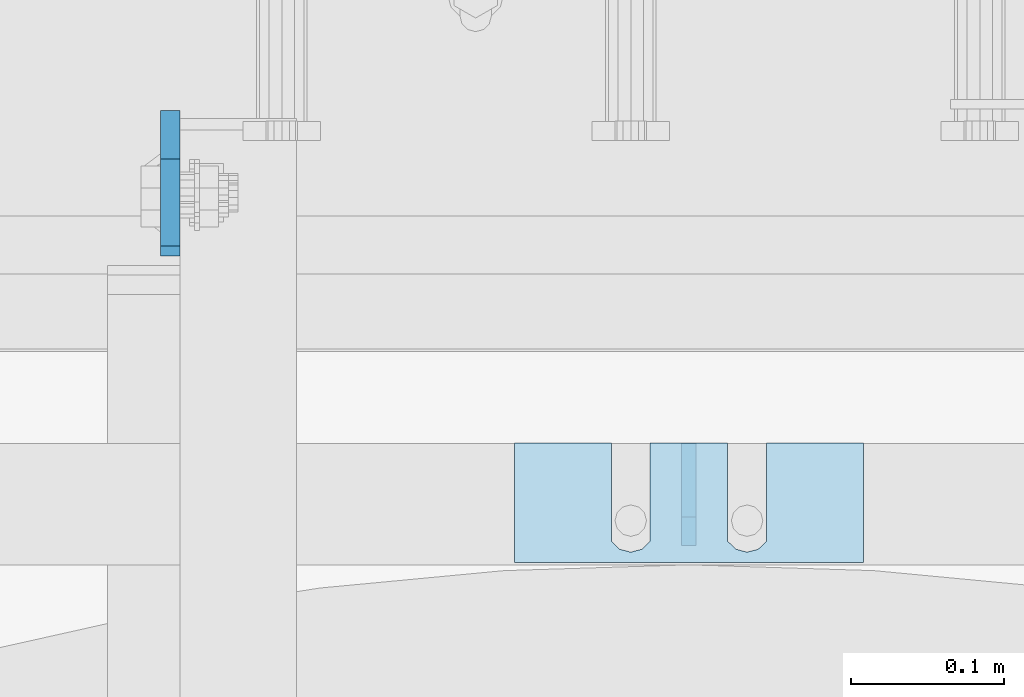
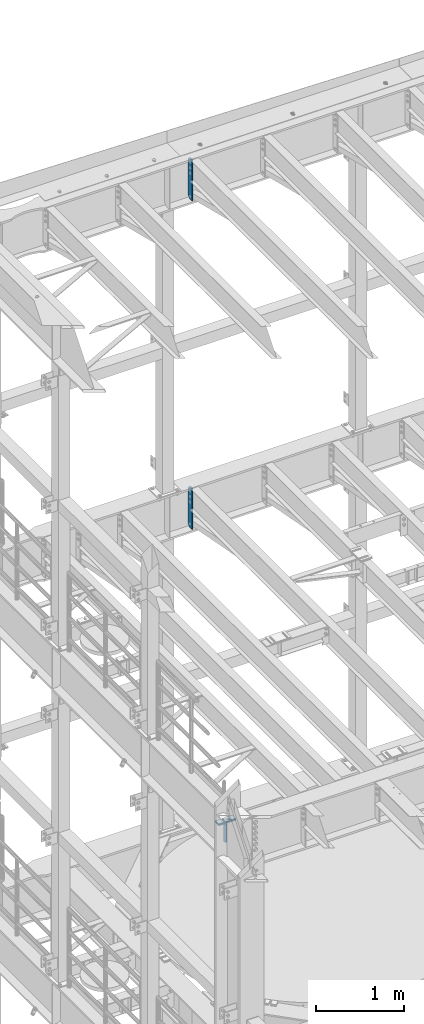
# One storey, part 1782 of 1876: 9 plates, 9 elements without a shape of their own.
"""IFC2X3 building model written with IfcOpenShell, lengths in millimetres."""

from ifc_helpers import new_model, si_unit, frame, origin_with_axes, place, context, subcontext, project, spatial, faceted_brep, material, type_object, element, aggregate, save


model = new_model("IFC2X3")

# Units and contexts
model_context = context("Model", 3, precision=1e-05, world=origin_with_axes())
body_context = subcontext(model_context, "Body", "Model", "MODEL_VIEW")
ifc_project = project(units=[si_unit("LENGTHUNIT", "METRE", prefix="MILLI"), si_unit("AREAUNIT", "SQUARE_METRE"), si_unit("VOLUMEUNIT", "CUBIC_METRE"), si_unit("MASSUNIT", "GRAM", prefix="KILO"), si_unit("TIMEUNIT", "SECOND"), si_unit("PLANEANGLEUNIT", "RADIAN"), si_unit("SOLIDANGLEUNIT", "STERADIAN"), si_unit("THERMODYNAMICTEMPERATUREUNIT", "DEGREE_CELSIUS"), si_unit("LUMINOUSINTENSITYUNIT", "LUMEN")], contexts=[model_context])

# Site, building, storey
site_placement = place(None, origin_with_axes())
site = spatial("IfcSite", under=ifc_project, at=site_placement, CompositionType="ELEMENT")
building_placement = place(site_placement, origin_with_axes())
building = spatial("IfcBuilding", under=site, at=building_placement, Name="Undefined", CompositionType="ELEMENT")
storey_placement = place(building_placement, origin_with_axes())
storey = spatial("IfcBuildingStorey", under=building, at=storey_placement, Name="Undefined", CompositionType="ELEMENT", Elevation=0.0)

# Assembly, plate
assembly_1_placement = place(storey_placement, origin_with_axes())
assembly_1 = element("IfcElementAssembly", 1, at=assembly_1_placement, inside=storey, Name="BEAM", AssemblyPlace="NOTDEFINED", PredefinedType="RIGID_FRAME")
ifc_material = material(Name="STEEL/A36")
plate_type_1 = type_object("IfcPlateType", PredefinedType="NOTDEFINED")
plate_1_placement = place(assembly_1_placement, frame((2847.97499990463, 13708.85625, 17386.3), z_axis=(0.0, 0.0, 1.0), x_axis=(0.0, -1.0, 0.0)))
plate_1 = element("IfcPlate", 2, at=plate_1_placement, type_object=plate_type_1, material=ifc_material, Name="PLATE", context=body_context, shape_type="Brep", body=[
    faceted_brep([(0.0, -6.34999999999991, 31.75), (0.0, -6.34999999999991, 539.75), (0.0, 6.34999999999991, 539.75), (0.0, 6.34999999999991, 31.75), (31.75, -6.34999999999991, 571.5), (31.75, 6.34999999999991, 571.5), (88.9000015258789, -6.34999999999991, 571.5), (88.9000015258789, 6.34999999999991, 571.5), (88.9000015258789, -6.34999999999991, 0.0), (88.9000015258789, 6.34999999999991, 0.0), (31.75, -6.34999999999991, 0.0), (31.75, 6.34999999999991, 0.0)], [[[0, 1, 2, 3]], [[1, 4, 5, 2]], [[4, 6, 7, 5]], [[6, 8, 9, 7]], [[8, 10, 11, 9]], [[10, 0, 3, 11]], [[5, 7, 9, 11, 3, 2]], [[10, 8, 6, 4, 1, 0]]]),
])
aggregate(assembly_1, [plate_1])

assembly_2_placement = place(storey_placement, origin_with_axes())
assembly_2 = element("IfcElementAssembly", 3, at=assembly_2_placement, inside=storey, Name="BEAM", AssemblyPlace="NOTDEFINED", PredefinedType="RIGID_FRAME")
plate_type_2 = type_object("IfcPlateType", PredefinedType="NOTDEFINED")
plate_2_placement = place(assembly_2_placement, frame((2847.97499990463, 13708.85625, 21959.8875), z_axis=(0.0, 0.0, 1.0), x_axis=(0.0, -1.0, 0.0)))
plate_2 = element("IfcPlate", 4, at=plate_2_placement, type_object=plate_type_2, material=ifc_material, Name="PLATE", context=body_context, shape_type="Brep", body=[
    faceted_brep([(0.0, -6.34999999999991, 31.75), (0.0, -6.35000000000036, 538.162475585938), (0.0, 6.35000000000036, 538.162475585938), (0.0, 6.34999999999991, 31.75), (31.75, -6.35000000000036, 569.912475585938), (31.75, 6.35000000000036, 569.912475585938), (95.25, -6.35000000000036, 569.912475585938), (95.25, 6.35000000000036, 569.912475585938), (95.25, -6.35000000000036, 0.0), (95.25, 6.35000000000036, 0.0), (31.75, -6.34999999999991, 0.0), (31.75, 6.34999999999991, 0.0)], [[[0, 1, 2, 3]], [[1, 4, 5, 2]], [[4, 6, 7, 5]], [[6, 8, 9, 7]], [[8, 10, 11, 9]], [[10, 0, 3, 11]], [[5, 7, 9, 11, 3, 2]], [[10, 8, 6, 4, 1, 0]]]),
])
aggregate(assembly_2, [plate_2])

assembly_3_placement = place(storey_placement, origin_with_axes())
assembly_3 = element("IfcElementAssembly", 5, at=assembly_3_placement, inside=storey, Name="SHIM PLATE", AssemblyPlace="NOTDEFINED", PredefinedType="RIGID_FRAME")
plate_type_3 = type_object("IfcPlateType", PredefinedType="NOTDEFINED")
plate_3_placement = place(assembly_3_placement, frame((3302.00186767578, 13490.9335073807, 13335.7925), z_axis=(-1.0, 0.0, 0.0), x_axis=(0.0, -1.0, 0.0)))
plate_3 = element("IfcPlate", 6, at=plate_3_placement, type_object=plate_type_3, material=ifc_material, Name="SHIM PLATE", context=body_context, shape_type="Brep", body=[
    faceted_brep([(-2.69435986410826e-07, -0.793499999999767, 88.9036802523933), (-2.69435986410826e-07, 0.793499999999767, 88.9036802523933), (64.2911367327433, 0.793499999999767, 88.9036792552815), (64.2911367327433, -0.793499999999767, 88.9036792552815), (69.5263870263134, 0.793499999999767, 83.4898931996304), (69.5263870263134, -0.793499999999767, 83.4898931996304), (64.2911372418785, -0.793499999999767, 63.5056518232686), (64.2911372418785, 0.793499999999767, 63.5056518232686), (-1.92456354852766e-07, 0.793499999999767, 63.5036806291719), (-1.92456354852766e-07, -0.793499999999767, 63.5036806291719), (69.5263873183976, -0.793499999999767, 68.9194380887848), (69.5263873183976, 0.793499999999767, 68.9194380887848), (71.4348903969494, -0.793499999999767, 76.2046656824614), (71.4348903969494, 0.793499999999767, 76.2046656824614), (64.2911372419712, -0.793499999999767, 139.705651823344), (64.2911372419712, 0.793499999999767, 139.705651823344), (-4.23393430537544e-07, 0.793499999999767, 139.703680607393), (-4.23393430537544e-07, -0.793499999999767, 139.703680607393), (69.5263873184904, -0.793499999999767, 145.119438088858), (69.5263873184904, 0.793499999999767, 145.119438088858), (71.434890397044, -0.793499999999767, 152.404665682535), (71.434890397044, 0.793499999999767, 152.404665682535), (69.5263870264062, -0.793499999999767, 159.689893199704), (69.5263870264062, 0.793499999999767, 159.689893199704), (64.2911367328379, -0.793499999999767, 165.103679255353), (64.2911367328379, 0.793499999999767, 165.103679255353), (-5.00373062095605e-07, -0.793499999999767, 165.103680230615), (-5.00373062095605e-07, 0.793499999999767, 165.103680230615), (-6.92811227054335e-07, -0.793499999999767, 228.601303100698), (-6.92811227054335e-07, 0.793499999999767, 228.601303100698), (78.1460113524699, -0.793499999999767, 228.601303100651), (78.1460113524699, 0.793499999999767, 228.601303100651), (78.1460113525918, -0.793499999999767, -4.91127138957381e-11), (78.1460113525918, 0.793499999999767, -4.91127138957381e-11), (9.09494701772928e-13, -0.793499999999767, 0.0), (9.09494701772928e-13, 0.793499999999767, 0.0)], [[[0, 1, 2, 3]], [[3, 2, 4, 5]], [[6, 7, 8, 9]], [[10, 11, 7, 6]], [[12, 13, 11, 10]], [[5, 4, 13, 12]], [[14, 15, 16, 17]], [[18, 19, 15, 14]], [[20, 21, 19, 18]], [[22, 23, 21, 20]], [[24, 25, 23, 22]], [[26, 27, 25, 24]], [[28, 29, 27, 26]], [[28, 30, 31, 29]], [[30, 32, 33, 31]], [[32, 34, 35, 33]], [[35, 34, 9, 8]], [[2, 1, 16, 15, 19, 21, 23, 25, 27, 29, 31, 33, 35, 8, 7, 11, 13, 4]], [[17, 16, 1, 0]], [[6, 9, 34, 32, 30, 28, 26, 24, 22, 20, 18, 14, 17, 0, 3, 5, 12, 10]]]),
])
aggregate(assembly_3, [plate_3])

assembly_4_placement = place(storey_placement, origin_with_axes())
assembly_4 = element("IfcElementAssembly", 7, at=assembly_4_placement, inside=storey, Name="SHIM PLATE", AssemblyPlace="NOTDEFINED", PredefinedType="RIGID_FRAME")
plate_type_4 = type_object("IfcPlateType", PredefinedType="NOTDEFINED")
plate_4_placement = place(assembly_4_placement, frame((3302.00186767578, 13490.9335073807, 13333.4115), z_axis=(-1.0, 0.0, 0.0), x_axis=(0.0, -1.0, 0.0)))
plate_4 = element("IfcPlate", 8, at=plate_4_placement, type_object=plate_type_4, material=ifc_material, Name="SHIM PLATE", context=body_context, shape_type="Brep", body=[
    faceted_brep([(-2.69435986410826e-07, -1.58749999999964, 88.9036802523951), (-2.69435986410826e-07, 1.58749999999964, 88.9036802523951), (64.2911367327433, 1.58749999999964, 88.9036792552824), (64.2911367327433, -1.58749999999964, 88.9036792552824), (69.5263870263134, 1.58749999999964, 83.4898931996322), (69.5263870263134, -1.58749999999964, 83.4898931996322), (64.2911372418766, -1.58749999999964, 63.5056518232714), (64.2911372418766, 1.58749999999964, 63.5056518232714), (-1.92456354852766e-07, 1.58749999999964, 63.5036806291737), (-1.92456354852766e-07, -1.58749999999964, 63.5036806291737), (69.5263873183958, -1.58749999999964, 68.9194380887884), (69.5263873183958, 1.58749999999964, 68.9194380887884), (71.4348903969494, -1.58749999999964, 76.2046656824641), (71.4348903969494, 1.58749999999964, 76.2046656824641), (64.2911372419694, -1.58749999999964, 139.705651823345), (64.2911372419694, 1.58749999999964, 139.705651823345), (-4.23391611548141e-07, 1.58749999999964, 139.703680607395), (-4.23391611548141e-07, -1.58749999999964, 139.703680607395), (69.5263873184886, -1.58749999999964, 145.119438088862), (69.5263873184886, 1.58749999999964, 145.119438088862), (71.434890397044, -1.58749999999964, 152.404665682537), (71.434890397044, 1.58749999999964, 152.404665682537), (69.5263870264062, -1.58749999999964, 159.689893199708), (69.5263870264062, 1.58749999999964, 159.689893199708), (64.2911367328361, -1.58749999999964, 165.103679255356), (64.2911367328361, 1.58749999999964, 165.103679255356), (-5.00371243106201e-07, -1.58749999999964, 165.103680230615), (-5.00371243106201e-07, 1.58749999999964, 165.103680230615), (-6.92813046043739e-07, -1.58749999999964, 228.601303100699), (-6.92813046043739e-07, 1.58749999999964, 228.601303100699), (78.1460113524699, -1.58749999999964, 228.601303100651), (78.1460113524699, 1.58749999999964, 228.601303100651), (78.1460113525918, -1.58749999999964, -4.72937244921923e-11), (78.1460113525918, 1.58749999999964, -4.72937244921923e-11), (9.09494701772928e-13, -1.58750000000146, 4.54747350886464e-13), (9.09494701772928e-13, 1.58750000000146, 4.54747350886464e-13)], [[[0, 1, 2, 3]], [[3, 2, 4, 5]], [[6, 7, 8, 9]], [[10, 11, 7, 6]], [[12, 13, 11, 10]], [[5, 4, 13, 12]], [[14, 15, 16, 17]], [[18, 19, 15, 14]], [[20, 21, 19, 18]], [[22, 23, 21, 20]], [[24, 25, 23, 22]], [[26, 27, 25, 24]], [[28, 29, 27, 26]], [[28, 30, 31, 29]], [[30, 32, 33, 31]], [[32, 34, 35, 33]], [[35, 34, 9, 8]], [[2, 1, 16, 15, 19, 21, 23, 25, 27, 29, 31, 33, 35, 8, 7, 11, 13, 4]], [[17, 16, 1, 0]], [[6, 9, 34, 32, 30, 28, 26, 24, 22, 20, 18, 14, 17, 0, 3, 5, 12, 10]]]),
])
aggregate(assembly_4, [plate_4])

assembly_5_placement = place(storey_placement, origin_with_axes())
assembly_5 = element("IfcElementAssembly", 9, at=assembly_5_placement, inside=storey, Name="SHIM PLATE", AssemblyPlace="NOTDEFINED", PredefinedType="RIGID_FRAME")
plate_5_placement = place(assembly_5_placement, frame((3302.00186767578, 13490.9335073807, 13330.2365), z_axis=(-1.0, 0.0, 0.0), x_axis=(0.0, -1.0, 0.0)))
plate_5 = element("IfcPlate", 10, at=plate_5_placement, type_object=plate_type_4, material=ifc_material, Name="SHIM PLATE", context=body_context, shape_type="Brep", body=[
    faceted_brep([(-2.69435986410826e-07, -1.58749999999964, 88.9036802523951), (-2.69435986410826e-07, 1.58749999999964, 88.9036802523951), (64.2911367327433, 1.58749999999964, 88.9036792552824), (64.2911367327433, -1.58749999999964, 88.9036792552824), (69.5263870263134, 1.58749999999964, 83.4898931996322), (69.5263870263134, -1.58749999999964, 83.4898931996322), (64.2911372418766, -1.58749999999964, 63.5056518232714), (64.2911372418766, 1.58749999999964, 63.5056518232714), (-1.92456354852766e-07, 1.58749999999964, 63.5036806291737), (-1.92456354852766e-07, -1.58749999999964, 63.5036806291737), (69.5263873183958, -1.58749999999964, 68.9194380887884), (69.5263873183958, 1.58749999999964, 68.9194380887884), (71.4348903969494, -1.58749999999964, 76.2046656824641), (71.4348903969494, 1.58749999999964, 76.2046656824641), (64.2911372419694, -1.58749999999964, 139.705651823345), (64.2911372419694, 1.58749999999964, 139.705651823345), (-4.23391611548141e-07, 1.58749999999964, 139.703680607395), (-4.23391611548141e-07, -1.58749999999964, 139.703680607395), (69.5263873184886, -1.58749999999964, 145.119438088862), (69.5263873184886, 1.58749999999964, 145.119438088862), (71.434890397044, -1.58749999999964, 152.404665682537), (71.434890397044, 1.58749999999964, 152.404665682537), (69.5263870264062, -1.58749999999964, 159.689893199708), (69.5263870264062, 1.58749999999964, 159.689893199708), (64.2911367328361, -1.58749999999964, 165.103679255356), (64.2911367328361, 1.58749999999964, 165.103679255356), (-5.00371243106201e-07, -1.58749999999964, 165.103680230615), (-5.00371243106201e-07, 1.58749999999964, 165.103680230615), (-6.92813046043739e-07, -1.58749999999964, 228.601303100699), (-6.92813046043739e-07, 1.58749999999964, 228.601303100699), (78.1460113524699, -1.58749999999964, 228.601303100651), (78.1460113524699, 1.58749999999964, 228.601303100651), (78.1460113525918, -1.58749999999964, -4.72937244921923e-11), (78.1460113525918, 1.58749999999964, -4.72937244921923e-11), (9.09494701772928e-13, -1.58750000000146, 4.54747350886464e-13), (9.09494701772928e-13, 1.58750000000146, 4.54747350886464e-13)], [[[0, 1, 2, 3]], [[3, 2, 4, 5]], [[6, 7, 8, 9]], [[10, 11, 7, 6]], [[12, 13, 11, 10]], [[5, 4, 13, 12]], [[14, 15, 16, 17]], [[18, 19, 15, 14]], [[20, 21, 19, 18]], [[22, 23, 21, 20]], [[24, 25, 23, 22]], [[26, 27, 25, 24]], [[28, 29, 27, 26]], [[28, 30, 31, 29]], [[30, 32, 33, 31]], [[32, 34, 35, 33]], [[35, 34, 9, 8]], [[2, 1, 16, 15, 19, 21, 23, 25, 27, 29, 31, 33, 35, 8, 7, 11, 13, 4]], [[17, 16, 1, 0]], [[6, 9, 34, 32, 30, 28, 26, 24, 22, 20, 18, 14, 17, 0, 3, 5, 12, 10]]]),
])
aggregate(assembly_5, [plate_5])

assembly_6_placement = place(storey_placement, origin_with_axes())
assembly_6 = element("IfcElementAssembly", 11, at=assembly_6_placement, inside=storey, Name="SHIM PLATE", AssemblyPlace="NOTDEFINED", PredefinedType="RIGID_FRAME")
plate_type_5 = type_object("IfcPlateType", PredefinedType="NOTDEFINED")
plate_6_placement = place(assembly_6_placement, frame((3302.00186767578, 13490.9335073807, 13326.268), z_axis=(-1.0, 0.0, 0.0), x_axis=(0.0, -1.0, 0.0)))
plate_6 = element("IfcPlate", 12, at=plate_6_placement, type_object=plate_type_5, material=ifc_material, Name="SHIM PLATE", context=body_context, shape_type="Brep", body=[
    faceted_brep([(-2.69435986410826e-07, -2.3809999999994, 88.9036802523951), (-2.69435986410826e-07, 2.3809999999994, 88.9036802523951), (64.2911367327433, 2.3809999999994, 88.9036792552824), (64.2911367327433, -2.3809999999994, 88.9036792552824), (69.5263870263134, 2.3809999999994, 83.4898931996322), (69.5263870263134, -2.3809999999994, 83.4898931996322), (64.2911372418766, -2.3809999999994, 63.5056518232714), (64.2911372418766, 2.3809999999994, 63.5056518232714), (-1.92456354852766e-07, 2.3809999999994, 63.5036806291737), (-1.92456354852766e-07, -2.3809999999994, 63.5036806291737), (69.5263873183958, -2.3809999999994, 68.9194380887884), (69.5263873183958, 2.3809999999994, 68.9194380887884), (71.4348903969494, -2.3809999999994, 76.2046656824641), (71.4348903969494, 2.3809999999994, 76.2046656824641), (64.2911372419694, -2.3809999999994, 139.705651823345), (64.2911372419694, 2.3809999999994, 139.705651823345), (-4.23391611548141e-07, 2.3809999999994, 139.703680607395), (-4.23391611548141e-07, -2.3809999999994, 139.703680607395), (69.5263873184886, -2.3809999999994, 145.119438088862), (69.5263873184886, 2.3809999999994, 145.119438088862), (71.434890397044, -2.3809999999994, 152.404665682537), (71.434890397044, 2.3809999999994, 152.404665682537), (69.5263870264062, -2.3809999999994, 159.689893199708), (69.5263870264062, 2.3809999999994, 159.689893199708), (64.2911367328361, -2.3809999999994, 165.103679255356), (64.2911367328361, 2.3809999999994, 165.103679255356), (-5.00371243106201e-07, -2.3809999999994, 165.103680230615), (-5.00371243106201e-07, 2.3809999999994, 165.103680230615), (-6.92813046043739e-07, -2.3809999999994, 228.601303100699), (-6.92813046043739e-07, 2.3809999999994, 228.601303100699), (78.1460113524699, -2.3809999999994, 228.601303100651), (78.1460113524699, 2.3809999999994, 228.601303100651), (78.1460113525918, -2.3809999999994, -4.72937244921923e-11), (78.1460113525918, 2.3809999999994, -4.72937244921923e-11), (0.0, -2.38100000000122, 4.54747350886464e-13), (0.0, 2.38100000000122, 4.54747350886464e-13)], [[[0, 1, 2, 3]], [[3, 2, 4, 5]], [[6, 7, 8, 9]], [[10, 11, 7, 6]], [[12, 13, 11, 10]], [[5, 4, 13, 12]], [[14, 15, 16, 17]], [[18, 19, 15, 14]], [[20, 21, 19, 18]], [[22, 23, 21, 20]], [[24, 25, 23, 22]], [[26, 27, 25, 24]], [[28, 29, 27, 26]], [[28, 30, 31, 29]], [[30, 32, 33, 31]], [[32, 34, 35, 33]], [[35, 34, 9, 8]], [[2, 1, 16, 15, 19, 21, 23, 25, 27, 29, 31, 33, 35, 8, 7, 11, 13, 4]], [[17, 16, 1, 0]], [[6, 9, 34, 32, 30, 28, 26, 24, 22, 20, 18, 14, 17, 0, 3, 5, 12, 10]]]),
])
aggregate(assembly_6, [plate_6])

assembly_7_placement = place(storey_placement, origin_with_axes())
assembly_7 = element("IfcElementAssembly", 13, at=assembly_7_placement, inside=storey, Name="SHIM PLATE", AssemblyPlace="NOTDEFINED", PredefinedType="RIGID_FRAME")
plate_7_placement = place(assembly_7_placement, frame((3302.00186767578, 13490.9335073807, 13321.506), z_axis=(-1.0, 0.0, 0.0), x_axis=(0.0, -1.0, 0.0)))
plate_7 = element("IfcPlate", 14, at=plate_7_placement, type_object=plate_type_5, material=ifc_material, Name="SHIM PLATE", context=body_context, shape_type="Brep", body=[
    faceted_brep([(-2.69435986410826e-07, -2.3809999999994, 88.9036802523951), (-2.69435986410826e-07, 2.3809999999994, 88.9036802523951), (64.2911367327433, 2.3809999999994, 88.9036792552824), (64.2911367327433, -2.3809999999994, 88.9036792552824), (69.5263870263134, 2.3809999999994, 83.4898931996322), (69.5263870263134, -2.3809999999994, 83.4898931996322), (64.2911372418766, -2.3809999999994, 63.5056518232714), (64.2911372418766, 2.3809999999994, 63.5056518232714), (-1.92456354852766e-07, 2.3809999999994, 63.5036806291737), (-1.92456354852766e-07, -2.3809999999994, 63.5036806291737), (69.5263873183958, -2.3809999999994, 68.9194380887884), (69.5263873183958, 2.3809999999994, 68.9194380887884), (71.4348903969494, -2.3809999999994, 76.2046656824641), (71.4348903969494, 2.3809999999994, 76.2046656824641), (64.2911372419694, -2.3809999999994, 139.705651823345), (64.2911372419694, 2.3809999999994, 139.705651823345), (-4.23391611548141e-07, 2.3809999999994, 139.703680607395), (-4.23391611548141e-07, -2.3809999999994, 139.703680607395), (69.5263873184886, -2.3809999999994, 145.119438088862), (69.5263873184886, 2.3809999999994, 145.119438088862), (71.434890397044, -2.3809999999994, 152.404665682537), (71.434890397044, 2.3809999999994, 152.404665682537), (69.5263870264062, -2.3809999999994, 159.689893199708), (69.5263870264062, 2.3809999999994, 159.689893199708), (64.2911367328361, -2.3809999999994, 165.103679255356), (64.2911367328361, 2.3809999999994, 165.103679255356), (-5.00371243106201e-07, -2.3809999999994, 165.103680230615), (-5.00371243106201e-07, 2.3809999999994, 165.103680230615), (-6.92813046043739e-07, -2.3809999999994, 228.601303100699), (-6.92813046043739e-07, 2.3809999999994, 228.601303100699), (78.1460113524699, -2.3809999999994, 228.601303100651), (78.1460113524699, 2.3809999999994, 228.601303100651), (78.1460113525918, -2.3809999999994, -4.72937244921923e-11), (78.1460113525918, 2.3809999999994, -4.72937244921923e-11), (0.0, -2.38100000000122, 4.54747350886464e-13), (0.0, 2.38100000000122, 4.54747350886464e-13)], [[[0, 1, 2, 3]], [[3, 2, 4, 5]], [[6, 7, 8, 9]], [[10, 11, 7, 6]], [[12, 13, 11, 10]], [[5, 4, 13, 12]], [[14, 15, 16, 17]], [[18, 19, 15, 14]], [[20, 21, 19, 18]], [[22, 23, 21, 20]], [[24, 25, 23, 22]], [[26, 27, 25, 24]], [[28, 29, 27, 26]], [[28, 30, 31, 29]], [[30, 32, 33, 31]], [[32, 34, 35, 33]], [[35, 34, 9, 8]], [[2, 1, 16, 15, 19, 21, 23, 25, 27, 29, 31, 33, 35, 8, 7, 11, 13, 4]], [[17, 16, 1, 0]], [[6, 9, 34, 32, 30, 28, 26, 24, 22, 20, 18, 14, 17, 0, 3, 5, 12, 10]]]),
])
aggregate(assembly_7, [plate_7])

assembly_8_placement = place(storey_placement, origin_with_axes())
assembly_8 = element("IfcElementAssembly", 15, at=assembly_8_placement, inside=storey, Name="SHIM PLATE", AssemblyPlace="NOTDEFINED", PredefinedType="RIGID_FRAME")
plate_type_6 = type_object("IfcPlateType", PredefinedType="NOTDEFINED")
plate_8_placement = place(assembly_8_placement, frame((3302.00186767578, 13490.9335073807, 13314.3625), z_axis=(-1.0, 0.0, 0.0), x_axis=(0.0, -1.0, 0.0)))
plate_8 = element("IfcPlate", 16, at=plate_8_placement, type_object=plate_type_6, material=ifc_material, Name="SHIM PLATE", context=body_context, shape_type="Brep", body=[
    faceted_brep([(-2.69435986410826e-07, -4.76250000000073, 88.9036802523951), (-2.69435986410826e-07, 4.76250000000073, 88.9036802523951), (64.2911367327433, 4.76250000000073, 88.9036792552824), (64.2911367327433, -4.76250000000073, 88.9036792552824), (69.5263870263134, 4.76250000000073, 83.4898931996322), (69.5263870263134, -4.76250000000073, 83.4898931996322), (64.2911372418766, -4.76250000000073, 63.5056518232714), (64.2911372418766, 4.76250000000073, 63.5056518232714), (-1.92456354852766e-07, 4.76250000000073, 63.5036806291737), (-1.92456354852766e-07, -4.76250000000073, 63.5036806291737), (69.5263873183958, -4.76250000000073, 68.9194380887884), (69.5263873183958, 4.76250000000073, 68.9194380887884), (71.4348903969494, -4.76250000000073, 76.2046656824641), (71.4348903969494, 4.76250000000073, 76.2046656824641), (64.2911372419694, -4.76250000000073, 139.705651823345), (64.2911372419694, 4.76250000000073, 139.705651823345), (-4.23391611548141e-07, 4.76250000000073, 139.703680607395), (-4.23391611548141e-07, -4.76250000000073, 139.703680607395), (69.5263873184886, -4.76250000000073, 145.119438088862), (69.5263873184886, 4.76250000000073, 145.119438088862), (71.434890397044, -4.76250000000073, 152.404665682537), (71.434890397044, 4.76250000000073, 152.404665682537), (69.5263870264062, -4.76250000000073, 159.689893199708), (69.5263870264062, 4.76250000000073, 159.689893199708), (64.2911367328361, -4.76250000000073, 165.103679255356), (64.2911367328361, 4.76250000000073, 165.103679255356), (-5.00371243106201e-07, -4.76250000000073, 165.103680230615), (-5.00371243106201e-07, 4.76250000000073, 165.103680230615), (-6.92813046043739e-07, -4.76250000000073, 228.601303100699), (-6.92813046043739e-07, 4.76250000000073, 228.601303100699), (78.1460113524699, -4.76250000000073, 228.601303100651), (78.1460113524699, 4.76250000000073, 228.601303100651), (78.1460113525918, -4.76250000000073, -4.72937244921923e-11), (78.1460113525918, 4.76250000000073, -4.72937244921923e-11), (0.0, -4.76249999999982, 0.0), (0.0, 4.76249999999982, 0.0)], [[[0, 1, 2, 3]], [[3, 2, 4, 5]], [[6, 7, 8, 9]], [[10, 11, 7, 6]], [[12, 13, 11, 10]], [[5, 4, 13, 12]], [[14, 15, 16, 17]], [[18, 19, 15, 14]], [[20, 21, 19, 18]], [[22, 23, 21, 20]], [[24, 25, 23, 22]], [[26, 27, 25, 24]], [[28, 29, 27, 26]], [[28, 30, 31, 29]], [[30, 32, 33, 31]], [[32, 34, 35, 33]], [[35, 34, 9, 8]], [[2, 1, 16, 15, 19, 21, 23, 25, 27, 29, 31, 33, 35, 8, 7, 11, 13, 4]], [[17, 16, 1, 0]], [[6, 9, 34, 32, 30, 28, 26, 24, 22, 20, 18, 14, 17, 0, 3, 5, 12, 10]]]),
])
aggregate(assembly_8, [plate_8])

assembly_9_placement = place(storey_placement, origin_with_axes())
assembly_9 = element("IfcElementAssembly", 17, at=assembly_9_placement, inside=storey, Name="BEAM", AssemblyPlace="NOTDEFINED", PredefinedType="RIGID_FRAME")
plate_type_7 = type_object("IfcPlateType", PredefinedType="NOTDEFINED")
plate_9_placement = place(assembly_9_placement, frame((3187.69999923622, 13490.5750070029, 13303.5119375), z_axis=(0.0, 0.164335003932503, -0.986404585594828), x_axis=(0.0, -0.986404585594828, -0.164335003932504)))
plate_9 = element("IfcPlate", 18, at=plate_9_placement, type_object=plate_type_7, material=ifc_material, Name="PLATE", context=body_context, shape_type="Brep", body=[
    faceted_brep([(0.0, -4.76249999999982, 0.0), (48.0883445741565, -4.76249999999982, 288.645538330276), (48.0883445741565, 4.76249999999982, 288.645538330276), (0.0, 4.76249999999982, 0.0), (94.0103563771863, -4.76249999999982, 272.907490929207), (94.0103563771863, 4.76249999999982, 272.907490929207), (108.900844089179, -4.76249999999982, 247.94043865757), (108.900844089179, 4.76249999999982, 247.94043865757), (70.7245526396091, -4.76249999999982, 18.7910066550394), (70.7245526396091, 4.76249999999982, 18.7910066550394), (48.5439720154172, -4.76249999999982, -2.91038304567337e-11), (48.5439720154172, 4.76249999999982, -2.91038304567337e-11)], [[[0, 1, 2, 3]], [[1, 4, 5, 2]], [[4, 6, 7, 5]], [[6, 8, 9, 7]], [[8, 10, 11, 9]], [[10, 0, 3, 11]], [[5, 7, 9, 11, 3, 2]], [[10, 8, 6, 4, 1, 0]]]),
])
aggregate(assembly_9, [plate_9])

save(model, "model.ifc")
